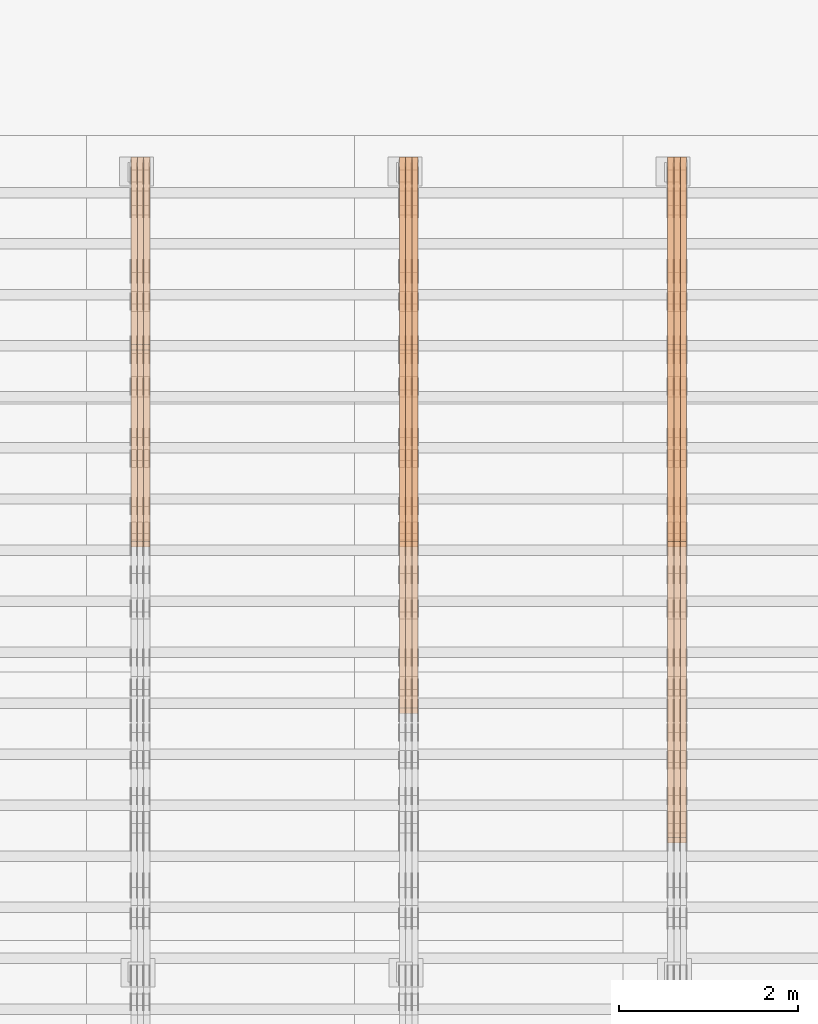
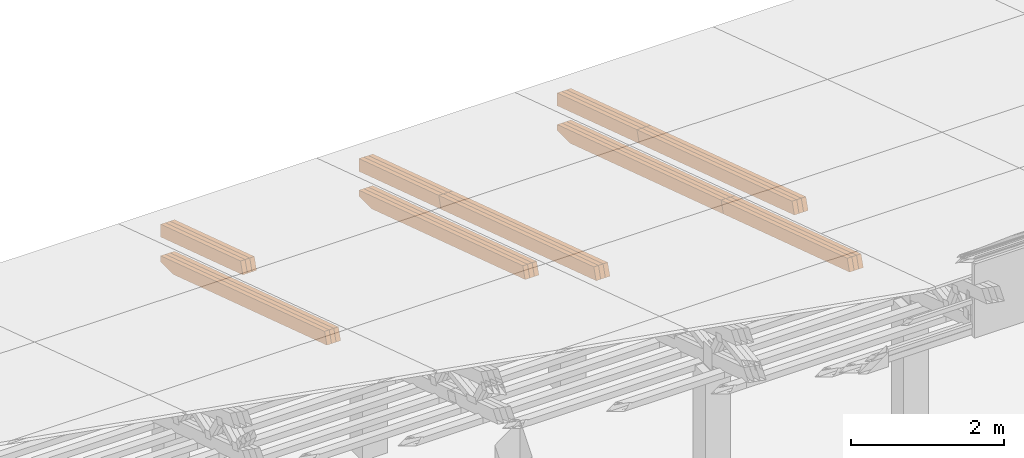
# One storey, part 30 of 385: 27 proxies.
"""IFC2X3 building model written with IfcOpenShell, lengths in millimetres."""

from ifc_helpers import new_model, entity, si_unit, converted_unit, derived_unit, direction, frame, origin, place, context, subcontext, project, spatial, polyline, outline, extrude, source, transform, mapped, material, type_object, type_shapes, element, save


model = new_model("IFC2X3")

# Units and contexts
model_context = context("Model", 3, precision=0.01, world=origin(), true_north=direction((6.12303176911189e-17, 1.0)))
body_context = subcontext(model_context, "Body", "Model", "MODEL_VIEW")
ifc_project = project(units=[si_unit("LENGTHUNIT", "METRE", prefix="MILLI"), si_unit("AREAUNIT", "SQUARE_METRE"), si_unit("VOLUMEUNIT", "CUBIC_METRE"), converted_unit("PLANEANGLEUNIT", "DEGREE", entity("IfcRatioMeasure", 0.0174532925199433), si_unit("PLANEANGLEUNIT", "RADIAN"), dimensions=[0, 0, 0, 0, 0, 0, 0]), si_unit("MASSUNIT", "GRAM", prefix="KILO"), derived_unit("MASSDENSITYUNIT", [(si_unit("MASSUNIT", "GRAM", prefix="KILO"), 1), (si_unit("LENGTHUNIT", "METRE"), -3)]), si_unit("TIMEUNIT", "SECOND"), si_unit("FREQUENCYUNIT", "HERTZ"), si_unit("THERMODYNAMICTEMPERATUREUNIT", "DEGREE_CELSIUS"), derived_unit("THERMALTRANSMITTANCEUNIT", [(si_unit("MASSUNIT", "GRAM", prefix="KILO"), 1), (si_unit("THERMODYNAMICTEMPERATUREUNIT", "KELVIN"), -1), (si_unit("TIMEUNIT", "SECOND"), -3)]), derived_unit("VOLUMETRICFLOWRATEUNIT", [(si_unit("LENGTHUNIT", "METRE"), 3), (si_unit("TIMEUNIT", "SECOND"), -1)]), si_unit("ELECTRICCURRENTUNIT", "AMPERE"), si_unit("ELECTRICVOLTAGEUNIT", "VOLT"), si_unit("POWERUNIT", "WATT"), si_unit("FORCEUNIT", "NEWTON", prefix="KILO"), si_unit("ILLUMINANCEUNIT", "LUX"), si_unit("LUMINOUSFLUXUNIT", "LUMEN"), si_unit("LUMINOUSINTENSITYUNIT", "CANDELA"), derived_unit("USERDEFINED", [(si_unit("MASSUNIT", "GRAM", prefix="KILO"), -1), (si_unit("LENGTHUNIT", "METRE"), -2), (si_unit("TIMEUNIT", "SECOND"), 3), (si_unit("LUMINOUSFLUXUNIT", "LUMEN"), 1)]), derived_unit("LINEARVELOCITYUNIT", [(si_unit("LENGTHUNIT", "METRE"), 1), (si_unit("TIMEUNIT", "SECOND"), -1)]), si_unit("PRESSUREUNIT", "PASCAL"), derived_unit("USERDEFINED", [(si_unit("LENGTHUNIT", "METRE"), -2), (si_unit("MASSUNIT", "GRAM", prefix="KILO"), 1), (si_unit("TIMEUNIT", "SECOND"), -2)])], contexts=[model_context])

# Site, building, storey
site_placement = place(None, origin())
site = spatial("IfcSite", under=ifc_project, at=site_placement, CompositionType="ELEMENT")
building_placement = place(site_placement, origin())
building = spatial("IfcBuilding", under=site, at=building_placement, CompositionType="ELEMENT")
storey_placement = place(building_placement, origin())
storey = spatial("IfcBuildingStorey", under=building, at=storey_placement, Name="Default", CompositionType="ELEMENT", Elevation=0.0)

# Proxies
ifc_material_1 = material(Name="IfcSurfaceStyle #455805")
building_element_proxy_type_1 = type_object("IfcBuildingElementProxyType", Name="T1-T2 455803", PredefinedType="NOTDEFINED", material=ifc_material_1)
shared_shape_1 = source(origin(), body_context, "Body", "SweptSolid", [
    extrude(outline(polyline([(-2137.04373183812, -97.5000250291418), (2137.04394104036, -97.5000250291418), (2137.04396402965, 97.5000250291418), (-2137.04417323189, 97.5000250291418), (-2137.04373183812, -97.5000250291418)])), frame((2137.04396402965, 97.5001541485632, 0.0), z_axis=(0.0, 0.0, 1.0), x_axis=(-1.0, 0.0, 0.0)), (0.0, 0.0, 1.0), 69.9999999999997),
])
type_shapes(building_element_proxy_type_1, [shared_shape_1])
proxy_1_placement = place(building_placement, frame((39385.0, 24344.7841397874, 1095.2368156767), z_axis=(-1.0, 0.0, 0.0), x_axis=(0.0, -0.951056516295154, 0.309016994374948)))
element("IfcBuildingElementProxy", 1, at=proxy_1_placement, inside=storey, type_object=building_element_proxy_type_1, material=ifc_material_1, Name="T1-T2", context=body_context, shape_type="MappedRepresentation", body=[
    mapped(shared_shape_1, transform((0.0, 0.0, 0.0), scale=1.0)),
])
ifc_material_2 = material(Name="IfcSurfaceStyle #455748")
building_element_proxy_type_2 = type_object("IfcBuildingElementProxyType", Name="T1-T2 455746", PredefinedType="NOTDEFINED", material=ifc_material_2)
shared_shape_2 = source(origin(), body_context, "Body", "SweptSolid", [
    extrude(outline(polyline([(-2137.04373183812, -97.5000250291418), (2137.04394104036, -97.5000250291418), (2137.04396402965, 97.5000250291418), (-2137.04417323189, 97.5000250291418), (-2137.04373183812, -97.5000250291418)])), frame((2137.04396402965, 97.5001541485632, 0.0), z_axis=(0.0, 0.0, 1.0), x_axis=(-1.0, 0.0, 0.0)), (0.0, 0.0, 1.0), 69.9999999999997),
])
type_shapes(building_element_proxy_type_2, [shared_shape_2])
proxy_2_placement = place(building_placement, frame((39315.0, 24344.7841397874, 1095.2368156767), z_axis=(-1.0, 0.0, 0.0), x_axis=(0.0, -0.951056516295154, 0.309016994374948)))
element("IfcBuildingElementProxy", 2, at=proxy_2_placement, inside=storey, type_object=building_element_proxy_type_2, material=ifc_material_2, Name="T1-T2", context=body_context, shape_type="MappedRepresentation", body=[
    mapped(shared_shape_2, transform((0.0, 0.0, 0.0), scale=1.0)),
])
ifc_material_3 = material(Name="IfcSurfaceStyle #455691")
building_element_proxy_type_3 = type_object("IfcBuildingElementProxyType", Name="T1-T2 455689", PredefinedType="NOTDEFINED", material=ifc_material_3)
shared_shape_3 = source(origin(), body_context, "Body", "SweptSolid", [
    extrude(outline(polyline([(-2137.04373183812, -97.5000250291418), (2137.04394104036, -97.5000250291418), (2137.04396402965, 97.5000250291418), (-2137.04417323189, 97.5000250291418), (-2137.04373183812, -97.5000250291418)])), frame((2137.04396402965, 97.5001541485632, 0.0), z_axis=(0.0, 0.0, 1.0), x_axis=(-1.0, 0.0, 0.0)), (0.0, 0.0, 1.0), 69.9999999999997),
])
type_shapes(building_element_proxy_type_3, [shared_shape_3])
proxy_3_placement = place(building_placement, frame((39245.0, 24344.7841397874, 1095.2368156767), z_axis=(-1.0, 0.0, 0.0), x_axis=(0.0, -0.951056516295154, 0.309016994374948)))
element("IfcBuildingElementProxy", 3, at=proxy_3_placement, inside=storey, type_object=building_element_proxy_type_3, material=ifc_material_3, Name="T1-T2", context=body_context, shape_type="MappedRepresentation", body=[
    mapped(shared_shape_3, transform((0.0, 0.0, 0.0), scale=1.0)),
])
ifc_material_4 = material(Name="IfcSurfaceStyle #455634")
building_element_proxy_type_4 = type_object("IfcBuildingElementProxyType", Name="T1-T3 455632", PredefinedType="NOTDEFINED", material=ifc_material_4)
shared_shape_4 = source(origin(), body_context, "Body", "SweptSolid", [
    extrude(outline(polyline([(-1117.22419189679, -97.5000115568039), (1085.54451125458, -97.5000115568039), (1148.90384954971, 97.5000115568039), (-1117.2241689075, 97.5000115568039), (-1117.22419189679, -97.5000115568039)])), frame((1148.90385201956, 97.5000191595882, 0.0), z_axis=(0.0, 0.0, 1.0), x_axis=(-1.0, 0.0, 0.0)), (0.0, 0.0, 1.0), 69.9999999999999),
])
type_shapes(building_element_proxy_type_4, [shared_shape_4])
proxy_4_placement = place(building_placement, frame((39385.0, 26500.0, 394.964866273674), z_axis=(-1.0, 0.0, 0.0), x_axis=(0.0, -0.951056516295154, 0.309016994374948)))
element("IfcBuildingElementProxy", 4, at=proxy_4_placement, inside=storey, type_object=building_element_proxy_type_4, material=ifc_material_4, Name="T1-T3", context=body_context, shape_type="MappedRepresentation", body=[
    mapped(shared_shape_4, transform((0.0, 0.0, 0.0), scale=1.0)),
])
ifc_material_5 = material(Name="IfcSurfaceStyle #455577")
building_element_proxy_type_5 = type_object("IfcBuildingElementProxyType", Name="T1-T3 455575", PredefinedType="NOTDEFINED", material=ifc_material_5)
shared_shape_5 = source(origin(), body_context, "Body", "SweptSolid", [
    extrude(outline(polyline([(-1117.22419189679, -97.5000115568039), (1085.54451125458, -97.5000115568039), (1148.90384954971, 97.5000115568039), (-1117.2241689075, 97.5000115568039), (-1117.22419189679, -97.5000115568039)])), frame((1148.90385201956, 97.5000191595882, 0.0), z_axis=(0.0, 0.0, 1.0), x_axis=(-1.0, 0.0, 0.0)), (0.0, 0.0, 1.0), 69.9999999999999),
])
type_shapes(building_element_proxy_type_5, [shared_shape_5])
proxy_5_placement = place(building_placement, frame((39315.0, 26500.0, 394.964866273674), z_axis=(-1.0, 0.0, 0.0), x_axis=(0.0, -0.951056516295154, 0.309016994374948)))
element("IfcBuildingElementProxy", 5, at=proxy_5_placement, inside=storey, type_object=building_element_proxy_type_5, material=ifc_material_5, Name="T1-T3", context=body_context, shape_type="MappedRepresentation", body=[
    mapped(shared_shape_5, transform((0.0, 0.0, 0.0), scale=1.0)),
])
ifc_material_6 = material(Name="IfcSurfaceStyle #455520")
building_element_proxy_type_6 = type_object("IfcBuildingElementProxyType", Name="T1-T3 455518", PredefinedType="NOTDEFINED", material=ifc_material_6)
shared_shape_6 = source(origin(), body_context, "Body", "SweptSolid", [
    extrude(outline(polyline([(-1117.22419189679, -97.5000115568039), (1085.54451125458, -97.5000115568039), (1148.90384954971, 97.5000115568039), (-1117.2241689075, 97.5000115568039), (-1117.22419189679, -97.5000115568039)])), frame((1148.90385201956, 97.5000191595882, 0.0), z_axis=(0.0, 0.0, 1.0), x_axis=(-1.0, 0.0, 0.0)), (0.0, 0.0, 1.0), 69.9999999999999),
])
type_shapes(building_element_proxy_type_6, [shared_shape_6])
proxy_6_placement = place(building_placement, frame((39245.0, 26500.0, 394.964866273674), z_axis=(-1.0, 0.0, 0.0), x_axis=(0.0, -0.951056516295154, 0.309016994374948)))
element("IfcBuildingElementProxy", 6, at=proxy_6_placement, inside=storey, type_object=building_element_proxy_type_6, material=ifc_material_6, Name="T1-T3", context=body_context, shape_type="MappedRepresentation", body=[
    mapped(shared_shape_6, transform((0.0, 0.0, 0.0), scale=1.0)),
])
ifc_material_7 = material(Name="IfcSurfaceStyle #454410")
building_element_proxy_type_7 = type_object("IfcBuildingElementProxyType", Name="T1-B2 454408", PredefinedType="NOTDEFINED", material=ifc_material_7)
shared_shape_7 = source(origin(), body_context, "Body", "SweptSolid", [
    extrude(outline(polyline([(-1738.61933402934, -97.4999466901035), (1738.6190788485, -97.4999466901035), (1738.6191018378, 97.4999466901035), (-1738.61884665697, 97.4999466901035), (-1738.61933402934, -97.4999466901035)])), frame((1738.6191018378, 97.4999528847471, 0.0), z_axis=(0.0, 0.0, 1.0), x_axis=(-1.0, 0.0, 0.0)), (0.0, 0.0, 1.0), 69.9999999999998),
])
type_shapes(building_element_proxy_type_7, [shared_shape_7])
proxy_7_placement = place(building_placement, frame((39385.0, 22140.4521465233, 1306.03026754604), z_axis=(-1.0, 0.0, 0.0), x_axis=(0.0, -0.951056516295124, 0.309016994375039)))
element("IfcBuildingElementProxy", 7, at=proxy_7_placement, inside=storey, type_object=building_element_proxy_type_7, material=ifc_material_7, Name="T1-B2", context=body_context, shape_type="MappedRepresentation", body=[
    mapped(shared_shape_7, transform((0.0, 0.0, 0.0), scale=1.0)),
])
ifc_material_8 = material(Name="IfcSurfaceStyle #454353")
building_element_proxy_type_8 = type_object("IfcBuildingElementProxyType", Name="T1-B2 454351", PredefinedType="NOTDEFINED", material=ifc_material_8)
shared_shape_8 = source(origin(), body_context, "Body", "SweptSolid", [
    extrude(outline(polyline([(-1738.61933402934, -97.4999466901035), (1738.6190788485, -97.4999466901035), (1738.6191018378, 97.4999466901035), (-1738.61884665697, 97.4999466901035), (-1738.61933402934, -97.4999466901035)])), frame((1738.6191018378, 97.4999528847471, 0.0), z_axis=(0.0, 0.0, 1.0), x_axis=(-1.0, 0.0, 0.0)), (0.0, 0.0, 1.0), 69.9999999999998),
])
type_shapes(building_element_proxy_type_8, [shared_shape_8])
proxy_8_placement = place(building_placement, frame((39315.0, 22140.4521465233, 1306.03026754604), z_axis=(-1.0, 0.0, 0.0), x_axis=(0.0, -0.951056516295124, 0.309016994375039)))
element("IfcBuildingElementProxy", 8, at=proxy_8_placement, inside=storey, type_object=building_element_proxy_type_8, material=ifc_material_8, Name="T1-B2", context=body_context, shape_type="MappedRepresentation", body=[
    mapped(shared_shape_8, transform((0.0, 0.0, 0.0), scale=1.0)),
])
ifc_material_9 = material(Name="IfcSurfaceStyle #454296")
building_element_proxy_type_9 = type_object("IfcBuildingElementProxyType", Name="T1-B2 454294", PredefinedType="NOTDEFINED", material=ifc_material_9)
shared_shape_9 = source(origin(), body_context, "Body", "SweptSolid", [
    extrude(outline(polyline([(-1738.61933402934, -97.4999466901035), (1738.6190788485, -97.4999466901035), (1738.6191018378, 97.4999466901035), (-1738.61884665697, 97.4999466901035), (-1738.61933402934, -97.4999466901035)])), frame((1738.6191018378, 97.4999528847471, 0.0), z_axis=(0.0, 0.0, 1.0), x_axis=(-1.0, 0.0, 0.0)), (0.0, 0.0, 1.0), 69.9999999999998),
])
type_shapes(building_element_proxy_type_9, [shared_shape_9])
proxy_9_placement = place(building_placement, frame((39245.0, 22140.4521465233, 1306.03026754604), z_axis=(-1.0, 0.0, 0.0), x_axis=(0.0, -0.951056516295124, 0.309016994375039)))
element("IfcBuildingElementProxy", 9, at=proxy_9_placement, inside=storey, type_object=building_element_proxy_type_9, material=ifc_material_9, Name="T1-B2", context=body_context, shape_type="MappedRepresentation", body=[
    mapped(shared_shape_9, transform((0.0, 0.0, 0.0), scale=1.0)),
])
ifc_material_10 = material(Name="IfcSurfaceStyle #454239")
building_element_proxy_type_10 = type_object("IfcBuildingElementProxyType", Name="T1-B1 454237", PredefinedType="NOTDEFINED", material=ifc_material_10)
shared_shape_10 = source(origin(), body_context, "Body", "SweptSolid", [
    extrude(outline(polyline([(-2659.34106034305, -95.9868650736445), (1861.19950396595, -95.9868650736445), (1890.42090463564, -6.05260867570997), (1567.0616890952, 99.0131694114995), (-2659.34103735375, 99.0131694114995), (-2659.34106034305, -95.9868650736445)])), frame((1890.42090463564, 99.013169411504, 0.0), z_axis=(0.0, 0.0, 1.0), x_axis=(-1.0, 0.0, 0.0)), (0.0, 0.0, 1.0), 69.9999999999997),
])
type_shapes(building_element_proxy_type_10, [shared_shape_10])
proxy_10_placement = place(building_placement, frame((39385.0, 26467.5328890438, -99.9234928894624), z_axis=(-1.0, 0.0, 0.0), x_axis=(0.0, -0.951056516295124, 0.309016994375039)))
element("IfcBuildingElementProxy", 10, at=proxy_10_placement, inside=storey, type_object=building_element_proxy_type_10, material=ifc_material_10, Name="T1-B1", context=body_context, shape_type="MappedRepresentation", body=[
    mapped(shared_shape_10, transform((0.0, 0.0, 0.0), scale=1.0)),
])
ifc_material_11 = material(Name="IfcSurfaceStyle #454173")
building_element_proxy_type_11 = type_object("IfcBuildingElementProxyType", Name="T1-B1 454171", PredefinedType="NOTDEFINED", material=ifc_material_11)
shared_shape_11 = source(origin(), body_context, "Body", "SweptSolid", [
    extrude(outline(polyline([(-2659.34106034305, -95.9868650736445), (1861.19950396595, -95.9868650736445), (1890.42090463564, -6.05260867570997), (1567.0616890952, 99.0131694114995), (-2659.34103735375, 99.0131694114995), (-2659.34106034305, -95.9868650736445)])), frame((1890.42090463564, 99.013169411504, 0.0), z_axis=(0.0, 0.0, 1.0), x_axis=(-1.0, 0.0, 0.0)), (0.0, 0.0, 1.0), 69.9999999999997),
])
type_shapes(building_element_proxy_type_11, [shared_shape_11])
proxy_11_placement = place(building_placement, frame((39315.0, 26467.5328890438, -99.9234928894624), z_axis=(-1.0, 0.0, 0.0), x_axis=(0.0, -0.951056516295124, 0.309016994375039)))
element("IfcBuildingElementProxy", 11, at=proxy_11_placement, inside=storey, type_object=building_element_proxy_type_11, material=ifc_material_11, Name="T1-B1", context=body_context, shape_type="MappedRepresentation", body=[
    mapped(shared_shape_11, transform((0.0, 0.0, 0.0), scale=1.0)),
])
ifc_material_12 = material(Name="IfcSurfaceStyle #454107")
building_element_proxy_type_12 = type_object("IfcBuildingElementProxyType", Name="T1-B1 454105", PredefinedType="NOTDEFINED", material=ifc_material_12)
shared_shape_12 = source(origin(), body_context, "Body", "SweptSolid", [
    extrude(outline(polyline([(-2659.34106034305, -95.9868650736445), (1861.19950396595, -95.9868650736445), (1890.42090463564, -6.05260867570997), (1567.0616890952, 99.0131694114995), (-2659.34103735375, 99.0131694114995), (-2659.34106034305, -95.9868650736445)])), frame((1890.42090463564, 99.013169411504, 0.0), z_axis=(0.0, 0.0, 1.0), x_axis=(-1.0, 0.0, 0.0)), (0.0, 0.0, 1.0), 69.9999999999997),
])
type_shapes(building_element_proxy_type_12, [shared_shape_12])
proxy_12_placement = place(building_placement, frame((39245.0, 26467.5328890438, -99.9234928894624), z_axis=(-1.0, 0.0, 0.0), x_axis=(0.0, -0.951056516295124, 0.309016994375039)))
element("IfcBuildingElementProxy", 12, at=proxy_12_placement, inside=storey, type_object=building_element_proxy_type_12, material=ifc_material_12, Name="T1-B1", context=body_context, shape_type="MappedRepresentation", body=[
    mapped(shared_shape_12, transform((0.0, 0.0, 0.0), scale=1.0)),
])
ifc_material_13 = material(Name="IfcSurfaceStyle #421373")
building_element_proxy_type_13 = type_object("IfcBuildingElementProxyType", Name="T1-T2 421371", PredefinedType="NOTDEFINED", material=ifc_material_13)
shared_shape_13 = source(origin(), body_context, "Body", "SweptSolid", [
    extrude(outline(polyline([(-2137.04373183812, -97.5000250291418), (2137.04394104036, -97.5000250291418), (2137.04396402965, 97.5000250291418), (-2137.04417323189, 97.5000250291418), (-2137.04373183812, -97.5000250291418)])), frame((2137.04396402965, 97.5001541485632, 0.0), z_axis=(0.0, 0.0, 1.0), x_axis=(-1.0, 0.0, 0.0)), (0.0, 0.0, 1.0), 69.9999999999997),
])
type_shapes(building_element_proxy_type_13, [shared_shape_13])
proxy_13_placement = place(building_placement, frame((36385.0, 24344.7841397874, 1095.2368156767), z_axis=(-1.0, 0.0, 0.0), x_axis=(0.0, -0.951056516295154, 0.309016994374948)))
element("IfcBuildingElementProxy", 13, at=proxy_13_placement, inside=storey, type_object=building_element_proxy_type_13, material=ifc_material_13, Name="T1-T2", context=body_context, shape_type="MappedRepresentation", body=[
    mapped(shared_shape_13, transform((0.0, 0.0, 0.0), scale=1.0)),
])
ifc_material_14 = material(Name="IfcSurfaceStyle #421316")
building_element_proxy_type_14 = type_object("IfcBuildingElementProxyType", Name="T1-T2 421314", PredefinedType="NOTDEFINED", material=ifc_material_14)
shared_shape_14 = source(origin(), body_context, "Body", "SweptSolid", [
    extrude(outline(polyline([(-2137.04373183812, -97.5000250291418), (2137.04394104036, -97.5000250291418), (2137.04396402965, 97.5000250291418), (-2137.04417323189, 97.5000250291418), (-2137.04373183812, -97.5000250291418)])), frame((2137.04396402965, 97.5001541485632, 0.0), z_axis=(0.0, 0.0, 1.0), x_axis=(-1.0, 0.0, 0.0)), (0.0, 0.0, 1.0), 69.9999999999997),
])
type_shapes(building_element_proxy_type_14, [shared_shape_14])
proxy_14_placement = place(building_placement, frame((36315.0, 24344.7841397874, 1095.2368156767), z_axis=(-1.0, 0.0, 0.0), x_axis=(0.0, -0.951056516295154, 0.309016994374948)))
element("IfcBuildingElementProxy", 14, at=proxy_14_placement, inside=storey, type_object=building_element_proxy_type_14, material=ifc_material_14, Name="T1-T2", context=body_context, shape_type="MappedRepresentation", body=[
    mapped(shared_shape_14, transform((0.0, 0.0, 0.0), scale=1.0)),
])
ifc_material_15 = material(Name="IfcSurfaceStyle #421259")
building_element_proxy_type_15 = type_object("IfcBuildingElementProxyType", Name="T1-T2 421257", PredefinedType="NOTDEFINED", material=ifc_material_15)
shared_shape_15 = source(origin(), body_context, "Body", "SweptSolid", [
    extrude(outline(polyline([(-2137.04373183812, -97.5000250291418), (2137.04394104036, -97.5000250291418), (2137.04396402965, 97.5000250291418), (-2137.04417323189, 97.5000250291418), (-2137.04373183812, -97.5000250291418)])), frame((2137.04396402965, 97.5001541485632, 0.0), z_axis=(0.0, 0.0, 1.0), x_axis=(-1.0, 0.0, 0.0)), (0.0, 0.0, 1.0), 69.9999999999997),
])
type_shapes(building_element_proxy_type_15, [shared_shape_15])
proxy_15_placement = place(building_placement, frame((36245.0, 24344.7841397874, 1095.2368156767), z_axis=(-1.0, 0.0, 0.0), x_axis=(0.0, -0.951056516295154, 0.309016994374948)))
element("IfcBuildingElementProxy", 15, at=proxy_15_placement, inside=storey, type_object=building_element_proxy_type_15, material=ifc_material_15, Name="T1-T2", context=body_context, shape_type="MappedRepresentation", body=[
    mapped(shared_shape_15, transform((0.0, 0.0, 0.0), scale=1.0)),
])
ifc_material_16 = material(Name="IfcSurfaceStyle #421202")
building_element_proxy_type_16 = type_object("IfcBuildingElementProxyType", Name="T1-T3 421200", PredefinedType="NOTDEFINED", material=ifc_material_16)
shared_shape_16 = source(origin(), body_context, "Body", "SweptSolid", [
    extrude(outline(polyline([(-1117.22419189679, -97.5000115568039), (1085.54451125458, -97.5000115568039), (1148.90384954971, 97.5000115568039), (-1117.2241689075, 97.5000115568039), (-1117.22419189679, -97.5000115568039)])), frame((1148.90385201956, 97.5000191595882, 0.0), z_axis=(0.0, 0.0, 1.0), x_axis=(-1.0, 0.0, 0.0)), (0.0, 0.0, 1.0), 69.9999999999999),
])
type_shapes(building_element_proxy_type_16, [shared_shape_16])
proxy_16_placement = place(building_placement, frame((36385.0, 26500.0, 394.964866273674), z_axis=(-1.0, 0.0, 0.0), x_axis=(0.0, -0.951056516295154, 0.309016994374948)))
element("IfcBuildingElementProxy", 16, at=proxy_16_placement, inside=storey, type_object=building_element_proxy_type_16, material=ifc_material_16, Name="T1-T3", context=body_context, shape_type="MappedRepresentation", body=[
    mapped(shared_shape_16, transform((0.0, 0.0, 0.0), scale=1.0)),
])
ifc_material_17 = material(Name="IfcSurfaceStyle #421145")
building_element_proxy_type_17 = type_object("IfcBuildingElementProxyType", Name="T1-T3 421143", PredefinedType="NOTDEFINED", material=ifc_material_17)
shared_shape_17 = source(origin(), body_context, "Body", "SweptSolid", [
    extrude(outline(polyline([(-1117.22419189679, -97.5000115568039), (1085.54451125458, -97.5000115568039), (1148.90384954971, 97.5000115568039), (-1117.2241689075, 97.5000115568039), (-1117.22419189679, -97.5000115568039)])), frame((1148.90385201956, 97.5000191595882, 0.0), z_axis=(0.0, 0.0, 1.0), x_axis=(-1.0, 0.0, 0.0)), (0.0, 0.0, 1.0), 69.9999999999999),
])
type_shapes(building_element_proxy_type_17, [shared_shape_17])
proxy_17_placement = place(building_placement, frame((36315.0, 26500.0, 394.964866273674), z_axis=(-1.0, 0.0, 0.0), x_axis=(0.0, -0.951056516295154, 0.309016994374948)))
element("IfcBuildingElementProxy", 17, at=proxy_17_placement, inside=storey, type_object=building_element_proxy_type_17, material=ifc_material_17, Name="T1-T3", context=body_context, shape_type="MappedRepresentation", body=[
    mapped(shared_shape_17, transform((0.0, 0.0, 0.0), scale=1.0)),
])
ifc_material_18 = material(Name="IfcSurfaceStyle #421088")
building_element_proxy_type_18 = type_object("IfcBuildingElementProxyType", Name="T1-T3 421086", PredefinedType="NOTDEFINED", material=ifc_material_18)
shared_shape_18 = source(origin(), body_context, "Body", "SweptSolid", [
    extrude(outline(polyline([(-1117.22419189679, -97.5000115568039), (1085.54451125458, -97.5000115568039), (1148.90384954971, 97.5000115568039), (-1117.2241689075, 97.5000115568039), (-1117.22419189679, -97.5000115568039)])), frame((1148.90385201956, 97.5000191595882, 0.0), z_axis=(0.0, 0.0, 1.0), x_axis=(-1.0, 0.0, 0.0)), (0.0, 0.0, 1.0), 69.9999999999999),
])
type_shapes(building_element_proxy_type_18, [shared_shape_18])
proxy_18_placement = place(building_placement, frame((36245.0, 26500.0, 394.964866273674), z_axis=(-1.0, 0.0, 0.0), x_axis=(0.0, -0.951056516295154, 0.309016994374948)))
element("IfcBuildingElementProxy", 18, at=proxy_18_placement, inside=storey, type_object=building_element_proxy_type_18, material=ifc_material_18, Name="T1-T3", context=body_context, shape_type="MappedRepresentation", body=[
    mapped(shared_shape_18, transform((0.0, 0.0, 0.0), scale=1.0)),
])
ifc_material_19 = material(Name="IfcSurfaceStyle #419807")
building_element_proxy_type_19 = type_object("IfcBuildingElementProxyType", Name="T1-B1 419805", PredefinedType="NOTDEFINED", material=ifc_material_19)
shared_shape_19 = source(origin(), body_context, "Body", "SweptSolid", [
    extrude(outline(polyline([(-2659.34106034305, -95.9868650736445), (1861.19950396595, -95.9868650736445), (1890.42090463564, -6.05260867570997), (1567.0616890952, 99.0131694114995), (-2659.34103735375, 99.0131694114995), (-2659.34106034305, -95.9868650736445)])), frame((1890.42090463564, 99.013169411504, 0.0), z_axis=(0.0, 0.0, 1.0), x_axis=(-1.0, 0.0, 0.0)), (0.0, 0.0, 1.0), 69.9999999999997),
])
type_shapes(building_element_proxy_type_19, [shared_shape_19])
proxy_19_placement = place(building_placement, frame((36385.0, 26467.5328890438, -99.9234928894624), z_axis=(-1.0, 0.0, 0.0), x_axis=(0.0, -0.951056516295124, 0.309016994375039)))
element("IfcBuildingElementProxy", 19, at=proxy_19_placement, inside=storey, type_object=building_element_proxy_type_19, material=ifc_material_19, Name="T1-B1", context=body_context, shape_type="MappedRepresentation", body=[
    mapped(shared_shape_19, transform((0.0, 0.0, 0.0), scale=1.0)),
])
ifc_material_20 = material(Name="IfcSurfaceStyle #419741")
building_element_proxy_type_20 = type_object("IfcBuildingElementProxyType", Name="T1-B1 419739", PredefinedType="NOTDEFINED", material=ifc_material_20)
shared_shape_20 = source(origin(), body_context, "Body", "SweptSolid", [
    extrude(outline(polyline([(-2659.34106034305, -95.9868650736445), (1861.19950396595, -95.9868650736445), (1890.42090463564, -6.05260867570997), (1567.0616890952, 99.0131694114995), (-2659.34103735375, 99.0131694114995), (-2659.34106034305, -95.9868650736445)])), frame((1890.42090463564, 99.013169411504, 0.0), z_axis=(0.0, 0.0, 1.0), x_axis=(-1.0, 0.0, 0.0)), (0.0, 0.0, 1.0), 69.9999999999997),
])
type_shapes(building_element_proxy_type_20, [shared_shape_20])
proxy_20_placement = place(building_placement, frame((36315.0, 26467.5328890438, -99.9234928894624), z_axis=(-1.0, 0.0, 0.0), x_axis=(0.0, -0.951056516295124, 0.309016994375039)))
element("IfcBuildingElementProxy", 20, at=proxy_20_placement, inside=storey, type_object=building_element_proxy_type_20, material=ifc_material_20, Name="T1-B1", context=body_context, shape_type="MappedRepresentation", body=[
    mapped(shared_shape_20, transform((0.0, 0.0, 0.0), scale=1.0)),
])
ifc_material_21 = material(Name="IfcSurfaceStyle #419675")
building_element_proxy_type_21 = type_object("IfcBuildingElementProxyType", Name="T1-B1 419673", PredefinedType="NOTDEFINED", material=ifc_material_21)
shared_shape_21 = source(origin(), body_context, "Body", "SweptSolid", [
    extrude(outline(polyline([(-2659.34106034305, -95.9868650736445), (1861.19950396595, -95.9868650736445), (1890.42090463564, -6.05260867570997), (1567.0616890952, 99.0131694114995), (-2659.34103735375, 99.0131694114995), (-2659.34106034305, -95.9868650736445)])), frame((1890.42090463564, 99.013169411504, 0.0), z_axis=(0.0, 0.0, 1.0), x_axis=(-1.0, 0.0, 0.0)), (0.0, 0.0, 1.0), 69.9999999999997),
])
type_shapes(building_element_proxy_type_21, [shared_shape_21])
proxy_21_placement = place(building_placement, frame((36245.0, 26467.5328890438, -99.9234928894624), z_axis=(-1.0, 0.0, 0.0), x_axis=(0.0, -0.951056516295124, 0.309016994375039)))
element("IfcBuildingElementProxy", 21, at=proxy_21_placement, inside=storey, type_object=building_element_proxy_type_21, material=ifc_material_21, Name="T1-B1", context=body_context, shape_type="MappedRepresentation", body=[
    mapped(shared_shape_21, transform((0.0, 0.0, 0.0), scale=1.0)),
])
ifc_material_22 = material(Name="IfcSurfaceStyle #386770")
building_element_proxy_type_22 = type_object("IfcBuildingElementProxyType", Name="T1-T3 386768", PredefinedType="NOTDEFINED", material=ifc_material_22)
shared_shape_22 = source(origin(), body_context, "Body", "SweptSolid", [
    extrude(outline(polyline([(-1117.22419189679, -97.5000115568039), (1085.54451125458, -97.5000115568039), (1148.90384954971, 97.5000115568039), (-1117.2241689075, 97.5000115568039), (-1117.22419189679, -97.5000115568039)])), frame((1148.90385201956, 97.5000191595882, 0.0), z_axis=(0.0, 0.0, 1.0), x_axis=(-1.0, 0.0, 0.0)), (0.0, 0.0, 1.0), 69.9999999999999),
])
type_shapes(building_element_proxy_type_22, [shared_shape_22])
proxy_22_placement = place(building_placement, frame((33385.0, 26500.0, 394.964866273674), z_axis=(-1.0, 0.0, 0.0), x_axis=(0.0, -0.951056516295154, 0.309016994374948)))
element("IfcBuildingElementProxy", 22, at=proxy_22_placement, inside=storey, type_object=building_element_proxy_type_22, material=ifc_material_22, Name="T1-T3", context=body_context, shape_type="MappedRepresentation", body=[
    mapped(shared_shape_22, transform((0.0, 0.0, 0.0), scale=1.0)),
])
ifc_material_23 = material(Name="IfcSurfaceStyle #386713")
building_element_proxy_type_23 = type_object("IfcBuildingElementProxyType", Name="T1-T3 386711", PredefinedType="NOTDEFINED", material=ifc_material_23)
shared_shape_23 = source(origin(), body_context, "Body", "SweptSolid", [
    extrude(outline(polyline([(-1117.22419189679, -97.5000115568039), (1085.54451125458, -97.5000115568039), (1148.90384954971, 97.5000115568039), (-1117.2241689075, 97.5000115568039), (-1117.22419189679, -97.5000115568039)])), frame((1148.90385201956, 97.5000191595882, 0.0), z_axis=(0.0, 0.0, 1.0), x_axis=(-1.0, 0.0, 0.0)), (0.0, 0.0, 1.0), 69.9999999999999),
])
type_shapes(building_element_proxy_type_23, [shared_shape_23])
proxy_23_placement = place(building_placement, frame((33315.0, 26500.0, 394.964866273674), z_axis=(-1.0, 0.0, 0.0), x_axis=(0.0, -0.951056516295154, 0.309016994374948)))
element("IfcBuildingElementProxy", 23, at=proxy_23_placement, inside=storey, type_object=building_element_proxy_type_23, material=ifc_material_23, Name="T1-T3", context=body_context, shape_type="MappedRepresentation", body=[
    mapped(shared_shape_23, transform((0.0, 0.0, 0.0), scale=1.0)),
])
ifc_material_24 = material(Name="IfcSurfaceStyle #386656")
building_element_proxy_type_24 = type_object("IfcBuildingElementProxyType", Name="T1-T3 386654", PredefinedType="NOTDEFINED", material=ifc_material_24)
shared_shape_24 = source(origin(), body_context, "Body", "SweptSolid", [
    extrude(outline(polyline([(-1117.22419189679, -97.5000115568039), (1085.54451125458, -97.5000115568039), (1148.90384954971, 97.5000115568039), (-1117.2241689075, 97.5000115568039), (-1117.22419189679, -97.5000115568039)])), frame((1148.90385201956, 97.5000191595882, 0.0), z_axis=(0.0, 0.0, 1.0), x_axis=(-1.0, 0.0, 0.0)), (0.0, 0.0, 1.0), 69.9999999999999),
])
type_shapes(building_element_proxy_type_24, [shared_shape_24])
proxy_24_placement = place(building_placement, frame((33245.0, 26500.0, 394.964866273674), z_axis=(-1.0, 0.0, 0.0), x_axis=(0.0, -0.951056516295154, 0.309016994374948)))
element("IfcBuildingElementProxy", 24, at=proxy_24_placement, inside=storey, type_object=building_element_proxy_type_24, material=ifc_material_24, Name="T1-T3", context=body_context, shape_type="MappedRepresentation", body=[
    mapped(shared_shape_24, transform((0.0, 0.0, 0.0), scale=1.0)),
])
ifc_material_25 = material(Name="IfcSurfaceStyle #385375")
building_element_proxy_type_25 = type_object("IfcBuildingElementProxyType", Name="T1-B1 385373", PredefinedType="NOTDEFINED", material=ifc_material_25)
shared_shape_25 = source(origin(), body_context, "Body", "SweptSolid", [
    extrude(outline(polyline([(-2659.34106034305, -95.9868650736445), (1861.19950396595, -95.9868650736445), (1890.42090463564, -6.05260867570997), (1567.0616890952, 99.0131694114995), (-2659.34103735375, 99.0131694114995), (-2659.34106034305, -95.9868650736445)])), frame((1890.42090463564, 99.013169411504, 0.0), z_axis=(0.0, 0.0, 1.0), x_axis=(-1.0, 0.0, 0.0)), (0.0, 0.0, 1.0), 69.9999999999997),
])
type_shapes(building_element_proxy_type_25, [shared_shape_25])
proxy_25_placement = place(building_placement, frame((33385.0, 26467.5328890438, -99.9234928894624), z_axis=(-1.0, 0.0, 0.0), x_axis=(0.0, -0.951056516295124, 0.309016994375039)))
element("IfcBuildingElementProxy", 25, at=proxy_25_placement, inside=storey, type_object=building_element_proxy_type_25, material=ifc_material_25, Name="T1-B1", context=body_context, shape_type="MappedRepresentation", body=[
    mapped(shared_shape_25, transform((0.0, 0.0, 0.0), scale=1.0)),
])
ifc_material_26 = material(Name="IfcSurfaceStyle #385309")
building_element_proxy_type_26 = type_object("IfcBuildingElementProxyType", Name="T1-B1 385307", PredefinedType="NOTDEFINED", material=ifc_material_26)
shared_shape_26 = source(origin(), body_context, "Body", "SweptSolid", [
    extrude(outline(polyline([(-2659.34106034305, -95.9868650736445), (1861.19950396595, -95.9868650736445), (1890.42090463564, -6.05260867570997), (1567.0616890952, 99.0131694114995), (-2659.34103735375, 99.0131694114995), (-2659.34106034305, -95.9868650736445)])), frame((1890.42090463564, 99.013169411504, 0.0), z_axis=(0.0, 0.0, 1.0), x_axis=(-1.0, 0.0, 0.0)), (0.0, 0.0, 1.0), 69.9999999999997),
])
type_shapes(building_element_proxy_type_26, [shared_shape_26])
proxy_26_placement = place(building_placement, frame((33315.0, 26467.5328890438, -99.9234928894624), z_axis=(-1.0, 0.0, 0.0), x_axis=(0.0, -0.951056516295124, 0.309016994375039)))
element("IfcBuildingElementProxy", 26, at=proxy_26_placement, inside=storey, type_object=building_element_proxy_type_26, material=ifc_material_26, Name="T1-B1", context=body_context, shape_type="MappedRepresentation", body=[
    mapped(shared_shape_26, transform((0.0, 0.0, 0.0), scale=1.0)),
])
ifc_material_27 = material(Name="IfcSurfaceStyle #385243")
building_element_proxy_type_27 = type_object("IfcBuildingElementProxyType", Name="T1-B1 385241", PredefinedType="NOTDEFINED", material=ifc_material_27)
shared_shape_27 = source(origin(), body_context, "Body", "SweptSolid", [
    extrude(outline(polyline([(-2659.34106034305, -95.9868650736445), (1861.19950396595, -95.9868650736445), (1890.42090463564, -6.05260867570997), (1567.0616890952, 99.0131694114995), (-2659.34103735375, 99.0131694114995), (-2659.34106034305, -95.9868650736445)])), frame((1890.42090463564, 99.013169411504, 0.0), z_axis=(0.0, 0.0, 1.0), x_axis=(-1.0, 0.0, 0.0)), (0.0, 0.0, 1.0), 69.9999999999997),
])
type_shapes(building_element_proxy_type_27, [shared_shape_27])
proxy_27_placement = place(building_placement, frame((33245.0, 26467.5328890438, -99.9234928894624), z_axis=(-1.0, 0.0, 0.0), x_axis=(0.0, -0.951056516295124, 0.309016994375039)))
element("IfcBuildingElementProxy", 27, at=proxy_27_placement, inside=storey, type_object=building_element_proxy_type_27, material=ifc_material_27, Name="T1-B1", context=body_context, shape_type="MappedRepresentation", body=[
    mapped(shared_shape_27, transform((0.0, 0.0, 0.0), scale=1.0)),
])

save(model, "model.ifc")
